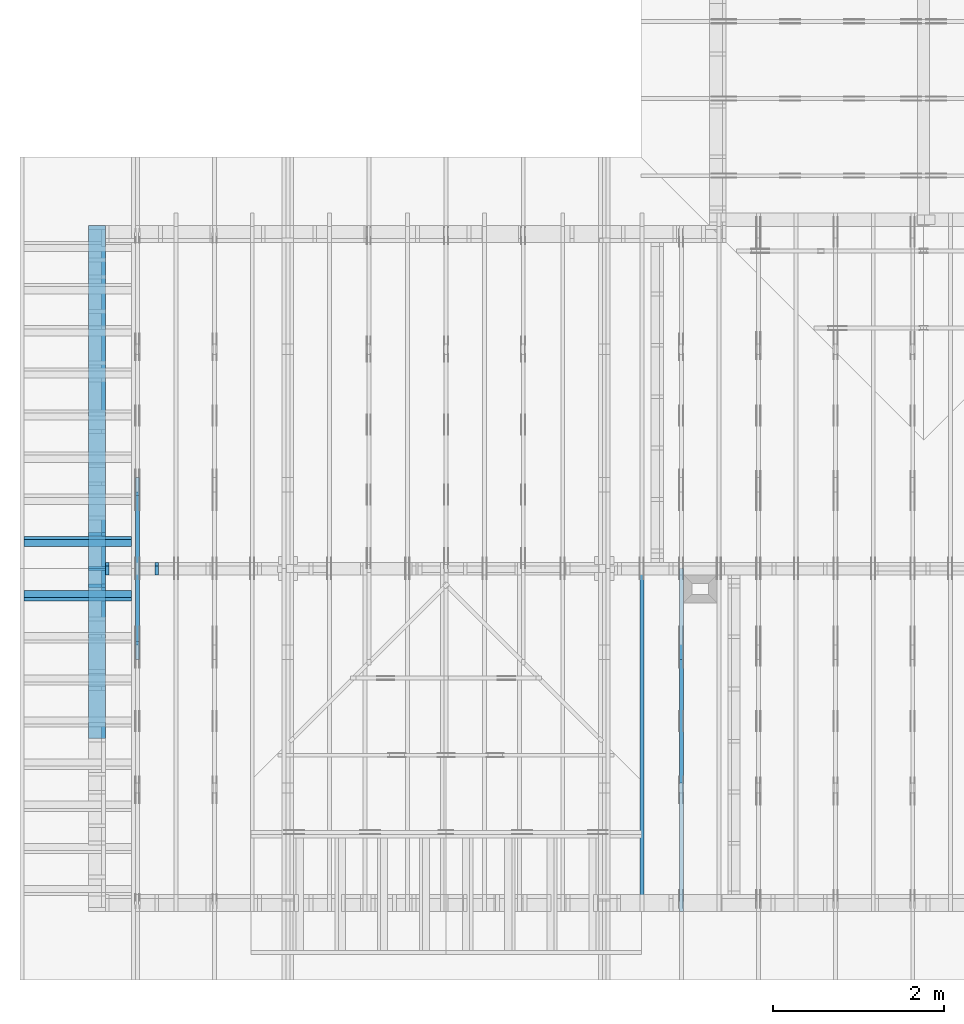
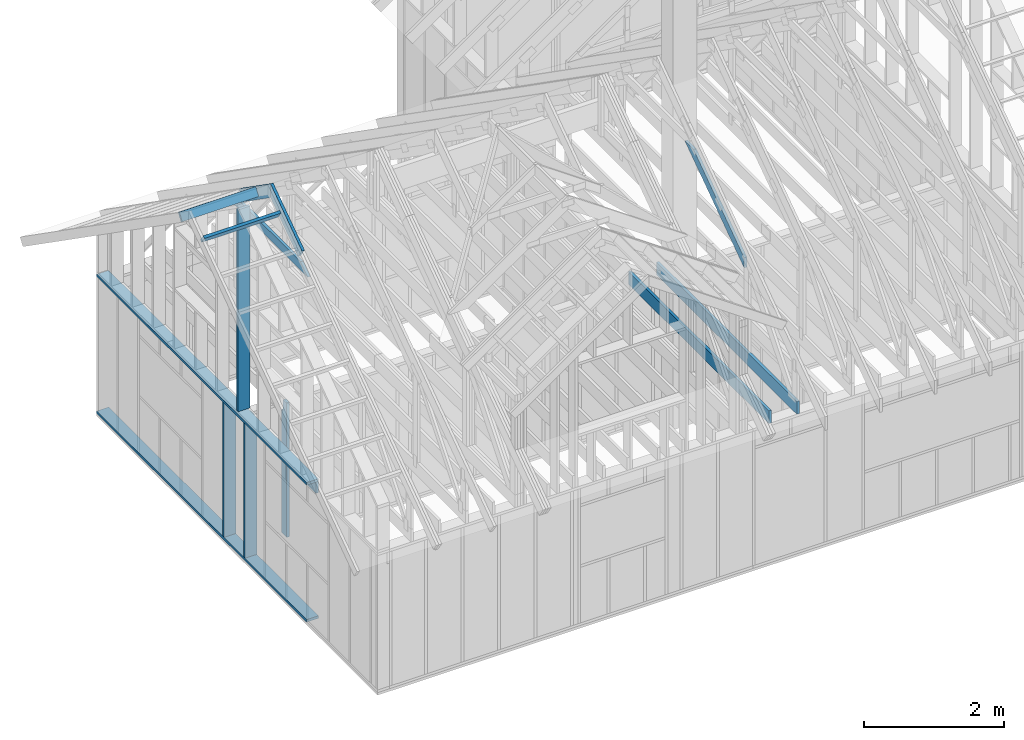
# One storey, part 10 of 70: 16 members, 8 elements without a shape of their own.
"""IFC2X3 building model written with IfcOpenShell, lengths in millimetres."""

import ifcopenshell
import ifcopenshell.guid

model = None  # the IFC model being written
_history = None  # IfcOwnerHistory: only IFC2X3 demands one
_inside = {}  # id of a spatial element -> (the spatial element, [elements in it])
_under = {}  # id of a project, library or spatial element -> (it, [spatial elements below it])
_declared = {}  # id of a project -> (the project, [libraries it declares])
_typed = {}  # id of a type object -> (the type object, [elements of that type])
_made_of = {}  # id of a material, layer set ... -> (it, [elements and type objects made of it])


def new_model(schema):
    """Start an empty IFC model of exactly this schema.

    Asked for "IFC4X3", IfcOpenShell would pick the latest addendum, in which some entities
    have other attributes; the version numbers below select the first issue.
    IFC2X3 requires an IfcOwnerHistory on every rooted entity: one is made here for all.
    """
    global model, _history
    if schema == "IFC4X3":
        model = ifcopenshell.file(schema_version=(4, 3, 0, 0))
    else:
        model = ifcopenshell.file(schema=schema)
    _inside.clear()
    _under.clear()
    _declared.clear()
    _typed.clear()
    _made_of.clear()
    _history = None
    if model.schema == "IFC2X3":
        org = make("IfcOrganization", Name="unknown")
        user = make(
            "IfcPersonAndOrganization",
            ThePerson=make("IfcPerson", FamilyName="unknown"),
            TheOrganization=org,
        )
        app = make(
            "IfcApplication",
            ApplicationDeveloper=org,
            Version="unknown",
            ApplicationFullName="unknown",
            ApplicationIdentifier="unknown",
        )
        _history = make(
            "IfcOwnerHistory",
            OwningUser=user,
            OwningApplication=app,
            ChangeAction="ADDED",
            CreationDate=0,
        )
    return model


def make(cls, **values):
    """One entity of the class cls with the attributes given. An attribute that is None is left unset."""
    return model.create_entity(
        cls, **{name: value for name, value in values.items() if value is not None}
    )


def rooted(cls, **values):
    """An entity with a GlobalId (a new one), such as an element, a storey or a relation."""
    return make(cls, GlobalId=ifcopenshell.guid.new(), OwnerHistory=_history, **values)


def si_unit(unit_type, name, prefix=None):
    """IfcSIUnit, for example si_unit("LENGTHUNIT", "METRE", prefix="MILLI")."""
    return make("IfcSIUnit", UnitType=unit_type, Prefix=prefix, Name=name)


def assignment(units):
    """IfcUnitAssignment: the units of a project."""
    return None if units is None else make("IfcUnitAssignment", Units=units)


def point(xyz):
    """IfcCartesianPoint."""
    return None if xyz is None else make("IfcCartesianPoint", Coordinates=xyz)


def direction(xyz):
    """IfcDirection."""
    return None if xyz is None else make("IfcDirection", DirectionRatios=xyz)


def frame(location, z_axis=None, x_axis=None):
    """IfcAxis2Placement3D, a coordinate frame: its origin and axes. An axis left out is left unset."""
    return make(
        "IfcAxis2Placement3D",
        Location=point(location),
        Axis=direction(z_axis),
        RefDirection=direction(x_axis),
    )


def frame_2d(location, x_axis=None):
    """IfcAxis2Placement2D, a coordinate frame in the plane: its origin and x axis."""
    return make(
        "IfcAxis2Placement2D", Location=point(location), RefDirection=direction(x_axis)
    )


def origin():
    """The frame at (0, 0, 0) with its axes left unset."""
    return frame((0.0, 0.0, 0.0))


def origin_with_axes():
    """The frame at (0, 0, 0) with the z axis (0, 0, 1) and the x axis (1, 0, 0) written out."""
    return frame((0.0, 0.0, 0.0), z_axis=(0.0, 0.0, 1.0), x_axis=(1.0, 0.0, 0.0))


def origin_2d():
    """The frame at (0, 0) in the plane with its x axis left unset."""
    return frame_2d((0.0, 0.0))


def place(relative_to, where):
    """IfcLocalPlacement: puts the frame where relative to a parent placement (None: the world)."""
    return make(
        "IfcLocalPlacement", PlacementRelTo=relative_to, RelativePlacement=where
    )


def context(
    kind, dimensions, precision=None, world=None, true_north=None, identifier=None
):
    """IfcGeometricRepresentationContext, for example the 3D "Model" context."""
    return make(
        "IfcGeometricRepresentationContext",
        ContextIdentifier=identifier,
        ContextType=kind,
        CoordinateSpaceDimension=dimensions,
        Precision=precision,
        WorldCoordinateSystem=world,
        TrueNorth=true_north,
    )


def project(units=None, contexts=None):
    """IfcProject with its units and contexts."""
    return rooted(
        "IfcProject",
        Name="project",
        RepresentationContexts=contexts,
        UnitsInContext=assignment(units),
    )


def spatial(cls, under=None, at=None, **own):
    """A site, building, storey or space (cls), placed at a placement, below another one or the project."""
    s = rooted(cls, ObjectPlacement=at, **own)
    if under is not None:
        _under.setdefault(under.id(), (under, []))[1].append(s)
    return s


def faces_of(points, faces, orient=None, outer=None):
    """IfcFace entities. A face is a list of loops; a loop is a list of indices into points, from 0.

    orient and outer hold one flag for each loop. By default every Orientation is true, the
    first loop of a face is its IfcFaceOuterBound and the others are IfcFaceBound.
    """
    made = []
    for i, loops in enumerate(faces):
        bounds = []
        for j, loop in enumerate(loops):
            is_outer = j == 0 if outer is None else outer[i][j]
            bounds.append(
                make(
                    "IfcFaceOuterBound" if is_outer else "IfcFaceBound",
                    Bound=make("IfcPolyLoop", Polygon=[points[k] for k in loop]),
                    Orientation=True if orient is None else orient[i][j],
                )
            )
        made.append(make("IfcFace", Bounds=bounds))
    return made


def faceted_brep(points, faces, orient=None, outer=None, voids=None):
    """IfcFacetedBrep: a solid bounded by flat faces; with voids (closed shells), ...WithVoids."""
    shared = [point(p) for p in points]
    hull = make("IfcClosedShell", CfsFaces=faces_of(shared, faces, orient, outer))
    if voids is None:
        return make("IfcFacetedBrep", Outer=hull)
    return make(
        "IfcFacetedBrepWithVoids",
        Outer=hull,
        Voids=[
            make(cls, CfsFaces=faces_of(shared, fs, o, b)) for cls, fs, o, b in voids
        ],
    )


def shape(context_of_items, identifier, shape_type, items):
    """IfcShapeRepresentation: the items that make up one representation, for example the "Body"."""
    return make(
        "IfcShapeRepresentation",
        ContextOfItems=context_of_items,
        RepresentationIdentifier=identifier,
        RepresentationType=shape_type,
        Items=items,
    )


def made_of(thing, what):
    """Note that an element or type object is made of a material, layer set ...; save() writes the relation."""
    if what is not None:
        _made_of.setdefault(what.id(), (what, []))[1].append(thing)
    return thing


def element(
    cls,
    number,
    at=None,
    inside=None,
    cuts=None,
    type_object=None,
    material=None,
    context=None,
    identifier="Body",
    shape_type=None,
    held_by="IfcProductDefinitionShape",
    body=None,
    shapes=None,
    **own,
):
    """One element of the class cls, such as IfcWall. Its Tag is "e" and its number.

    at: its placement. inside: the storey or other place that contains it. cuts: it is an
    opening in that element (IfcRelVoidsElement). A single representation is given by context,
    identifier, shape_type and body (its items); several are given by shapes. held_by: the class
    of the entity that holds the representations. save() writes the other relations.
    """
    e = rooted(cls, Tag="e%d" % number, ObjectPlacement=at, **own)
    if body is not None:
        shapes = [shape(context, identifier, shape_type, body)]
    if shapes is not None:
        e.Representation = make(held_by, Representations=shapes)
    if inside is not None:
        _inside.setdefault(inside.id(), (inside, []))[1].append(e)
    if cuts is not None:
        rooted(
            "IfcRelVoidsElement", RelatingBuildingElement=cuts, RelatedOpeningElement=e
        )
    if type_object is not None:
        _typed.setdefault(type_object.id(), (type_object, []))[1].append(e)
    return made_of(e, material)


def aggregate(whole, parts):
    """IfcRelAggregates: a whole, such as a stair, and the parts it consists of."""
    return rooted("IfcRelAggregates", RelatingObject=whole, RelatedObjects=parts)


def save(model, path):
    """Write the relations noted so far, then the file.

    IfcRelAggregates (storeys below a building ...), IfcRelContainedInSpatialStructure (elements
    in a storey), IfcRelDefinesByType, IfcRelAssociatesMaterial and IfcRelDeclares: one each for
    every whole, place, type object, material and project.
    """
    for whole, parts in _under.values():
        aggregate(whole, parts)
    for where, things in _inside.values():
        rooted(
            "IfcRelContainedInSpatialStructure",
            RelatedElements=things,
            RelatingStructure=where,
        )
    for kind, things in _typed.values():
        rooted("IfcRelDefinesByType", RelatedObjects=things, RelatingType=kind)
    for what, things in _made_of.values():
        rooted("IfcRelAssociatesMaterial", RelatedObjects=things, RelatingMaterial=what)
    for by, libraries in _declared.values():
        rooted("IfcRelDeclares", RelatingContext=by, RelatedDefinitions=libraries)
    model.write(path)


model = new_model("IFC2X3")

# Units and contexts
model_context = context("Model", 3, precision=1e-05, world=origin())
plan_context = context("Plan", 2, precision=1e-05, world=origin_2d())
ifc_project = project(units=[si_unit("LENGTHUNIT", "METRE", prefix="MILLI"), si_unit("AREAUNIT", "SQUARE_METRE"), si_unit("VOLUMEUNIT", "CUBIC_METRE"), si_unit("SOLIDANGLEUNIT", "STERADIAN"), si_unit("PLANEANGLEUNIT", "RADIAN"), si_unit("MASSUNIT", "GRAM"), si_unit("TIMEUNIT", "SECOND"), si_unit("THERMODYNAMICTEMPERATUREUNIT", "DEGREE_CELSIUS"), si_unit("LUMINOUSINTENSITYUNIT", "LUMEN")], contexts=[model_context, plan_context])

# Site, building, storey
site_placement = place(None, origin_with_axes())
site = spatial("IfcSite", under=ifc_project, at=site_placement, CompositionType="ELEMENT")
building_placement = place(site_placement, origin_with_axes())
building = spatial("IfcBuilding", under=site, at=building_placement, Name="Layout 1", CompositionType="ELEMENT")
storey_placement = place(building_placement, origin_with_axes())
storey = spatial("IfcBuildingStorey", under=building, at=storey_placement, Name="Storey 1", CompositionType="ELEMENT", Elevation=0.0)

# Assembly, members
assembly_1_placement = place(storey_placement, frame((304.9999999999989, 8000.000000000001, 1.3776821480501744e-15), z_axis=(-1.0, 1.836909530733566e-16, 6.123031769111886e-17), x_axis=(-1.836909530733566e-16, -1.0, 0.0)))
assembly_1 = element("IfcElementAssembly", 1, at=assembly_1_placement, inside=storey, Name="T2", AssemblyPlace="FACTORY", PredefinedType="TRUSS")
member_1_placement = place(assembly_1_placement, frame((3217.690358731264, 3015.0000000002183, -45.00000000000001), z_axis=(0.0, 0.0, 1.0), x_axis=(0.8191520442889918, 0.5735764363510462, 0.0)))
member_1 = element("IfcMember", 2, at=member_1_placement, Name="T18", context=model_context, shape_type="Brep", body=[
    faceted_brep([(1091.564200553914, 194.99999999865213, 45.0), (0.0, 194.99999999865213, 45.0), (1.6370904631912708e-10, 7.557900971733034e-10, 45.0), (955.0237306039635, 7.557900971733034e-10, 45.0), (0.0, 194.99999999865213, 0.0), (1091.564200553914, 194.99999999865213, 1.3367364556033665e-13), (955.0237306039635, 7.557900971733034e-10, 1.169528128548764e-13), (1.6370904631912708e-10, 7.557900971733034e-10, 2.004791383006049e-26), (1.6370904631912732e-10, 7.557900971733033e-10, -1.4349296274686127e-41), (1.6371180168342342e-10, 7.557900971733033e-10, 45.0), (6.660321774678196e-14, 194.99999999996407, 45.0), (6.384785345068161e-14, 194.99999999996407, -3.909424350681179e-30), (955.0237306039635, -1.5956987698560245e-13, 9.770514261762543e-30), (955.0237306039635, -1.568145126895021e-13, 45.0), (1.6370904631912708e-10, 7.557928525375995e-10, 45.0), (1.6370904631912708e-10, 7.557900971733034e-10, 0.0), (1091.564200553914, 194.99999999865213, 0.0), (1091.564200553914, 194.99999999865213, 45.0), (955.0237306039635, -5.684341886080802e-14, 45.0), (955.0237306039635, -5.684341886080802e-14, -6.310887241768095e-30), (0.0, 194.99999999996407, 0.0), (0.0, 194.99999999996407, 45.0), (1091.564200553914, 194.99999999865202, 45.0), (1091.564200553914, 194.99999999865202, -6.310887241768095e-30)], [[[0, 1, 2, 3]], [[4, 5, 6, 7]], [[8, 9, 10, 11]], [[12, 13, 14, 15]], [[16, 17, 18, 19]], [[20, 21, 22, 23]]]),
])
member_2_placement = place(assembly_1_placement, frame((3888.1525949105694, 3641.0955042035366, -45.00000000000001), z_axis=(0.0, 0.0, 1.0), x_axis=(0.8191520442889916, -0.5735764363510465, 0.0)))
member_2 = element("IfcMember", 3, at=member_2_placement, Name="T18", context=model_context, shape_type="Brep", body=[
    faceted_brep([(1091.5642005560503, 194.99999999996362, 45.0), (0.0, 194.99999999996362, 45.0), (136.54046995208614, 0.0, 45.0), (1091.5642005561149, 0.0, 45.0), (0.0, 194.99999999996362, 0.0), (1091.5642005560503, 194.99999999996362, 1.336736455605983e-13), (1091.5642005561149, 0.0, 1.336736455606062e-13), (136.54046995208614, 0.0, 1.6720832705721806e-14), (136.54046995208614, -2.842170943040401e-14, 3.0619884913871384e-31), (136.54046995208614, -2.842170943040401e-14, 45.0), (1.4210854715202004e-14, 195.00000000170263, 45.0), (1.4210854715202004e-14, 195.00000000170263, -5.932810329456638e-31), (1091.5642005561149, 2.0525182992035534e-09, 1.2934457505131873e-29), (1091.5642005561149, 2.0525210545678495e-09, 45.0), (136.54046995208614, -2.3668346958569874e-14, 45.0), (136.54046995208614, -2.6423711254670222e-14, 1.6179322347011683e-30), (1091.5642005561149, 194.99999999996362, 3.950615413346827e-27), (1091.5642005561149, 194.99999999996362, 45.0), (1091.5642005561149, 2.052729541901499e-09, 45.0), (1091.5642005561149, 2.052729541901499e-09, 0.0), (0.0, 195.00000000170257, 0.0), (0.0, 195.00000000170257, 45.0), (1091.5642005560503, 194.9999999999637, 45.0), (1091.5642005560503, 194.9999999999637, 6.310887241768095e-30)], [[[0, 1, 2, 3]], [[4, 5, 6, 7]], [[8, 9, 10, 11]], [[12, 13, 14, 15]], [[16, 17, 18, 19]], [[20, 21, 22, 23]]]),
])
member_3_placement = place(assembly_1_placement, frame((5060.798502586593, 2964.999999998785, -45.0), z_axis=(0.0, 0.0, 1.0), x_axis=(-1.0, 1.2246063538223773e-16, 0.0)))
member_3 = element("IfcMember", 4, at=member_3_placement, Name="C1", context=model_context, shape_type="Brep", body=[
    faceted_brep([(2121.597005175296, 145.00000000000728, 45.0), (0.0, 145.00000000000728, 45.0), (207.08146097743884, 0.0, 45.0), (1914.5155441979737, 0.0, 45.0), (0.0, 145.00000000000728, 0.0), (2121.597005175296, 145.00000000000728, 2.5981211727881944e-13), (1914.5155441979737, 0.0, 2.3445278999165447e-13), (207.08146097743884, 0.0, 2.5359327287179227e-14), (207.08146097743878, -7.105427357601002e-14, 3.1554436208840472e-30), (207.08146097743878, -7.105427357601002e-14, 45.0), (1.4210854715202004e-14, 145.00000000000728, 45.0), (1.4210854715202004e-14, 145.00000000000728, 0.0), (1914.5155441979737, 7.26803319922997e-12, 4.8521444511629875e-31), (1914.5155441979737, 7.27078856352607e-12, 45.0), (207.08146097743884, 1.898228698049977e-15, 45.0), (207.08146097743884, -8.571355980503717e-16, 5.248268497299439e-32), (2121.597005175296, 145.00000000000728, 0.0), (2121.597005175296, 145.00000000000728, 45.0), (1914.515544197974, 7.389644451905042e-12, 45.0), (1914.515544197974, 7.389644451905042e-12, 1.262177448353619e-29), (0.0, 145.00000000000728, 0.0), (-1.6871183120499046e-31, 145.00000000000728, 45.0), (2121.597005175296, 145.00000000000713, 45.0), (2121.597005175296, 145.00000000000713, -7.888609052210118e-30)], [[[0, 1, 2, 3]], [[4, 5, 6, 7]], [[8, 9, 10, 11]], [[12, 13, 14, 15]], [[16, 17, 18, 19]], [[20, 21, 22, 23]]]),
])
aggregate(assembly_1, [member_1, member_2, member_3])

# Assembly, member
assembly_2_placement = place(storey_placement, frame((6188.750000000146, 8000.0, 1.3776821480501744e-15), z_axis=(-1.0, 1.836909530733566e-16, 6.123031769111886e-17), x_axis=(-1.836909530733566e-16, -1.0, 0.0)))
assembly_2 = element("IfcElementAssembly", 5, at=assembly_2_placement, inside=storey, Name="MB1", AssemblyPlace="FACTORY", PredefinedType="TRUSS")
member_4_placement = place(assembly_2_placement, frame((8000.000000000001, 220.0, -45.0), z_axis=(0.0, 0.0, 1.0), x_axis=(-1.0, 1.2246063538223773e-16, 0.0)))
member_4 = element("IfcMember", 6, at=member_4_placement, Name="B3", context=model_context, shape_type="Brep", body=[
    faceted_brep([(4000.0000000000005, 220.0000000000005, 45.0), (0.0, 220.0000000000005, 45.0), (0.0, 0.0, 45.0), (4000.0000000000005, 0.0, 45.0), (0.0, 220.0000000000005, 0.0), (4000.0000000000005, 220.0000000000005, 4.89842541528951e-13), (4000.0000000000005, 0.0, 4.89842541528951e-13), (0.0, 0.0, 0.0), (0.0, 0.0, 0.0), (2.755364296100349e-15, -3.3742366240998092e-31, 45.0), (2.969670408019265e-14, 220.0, 45.0), (2.69413397840923e-14, 220.0, -1.6496267940043512e-30), (4000.0000000000005, -7.347638122934265e-13, 7.631468701413364e-29), (4000.0000000000005, -7.320084479973261e-13, 45.0), (5.061354936149714e-31, 2.755364296100349e-15, 45.0), (0.0, 0.0, 0.0), (4000.0000000000005, 220.0000000000005, 0.0), (4000.0000000000005, 220.0000000000005, 45.0), (4000.0000000000005, 5.115907697472721e-13, 45.0), (4000.0000000000005, 5.115907697472721e-13, 0.0), (0.0, 220.0, 0.0), (0.0, 220.0, 45.0), (4000.0000000000005, 220.00000000000065, 45.0), (4000.0000000000005, 220.00000000000065, 7.888609052210118e-30)], [[[0, 1, 2, 3]], [[4, 5, 6, 7]], [[8, 9, 10, 11]], [[12, 13, 14, 15]], [[16, 17, 18, 19]], [[20, 21, 22, 23]]]),
])
aggregate(assembly_2, [member_4])

# Assembly, members
assembly_3_placement = place(storey_placement, frame((-243.55339059327574, 8000.000000000001, -2470.0), z_axis=(-1.0, 1.836909530733566e-16, 6.123031769111886e-17), x_axis=(-1.836909530733566e-16, -1.0, 0.0)))
assembly_3 = element("IfcElementAssembly", 7, at=assembly_3_placement, inside=storey, Name="VE3", AssemblyPlace="FACTORY", PredefinedType="NOTDEFINED")
member_5_placement = place(assembly_3_placement, frame((1.457281561048629e-13, 2425.0, -195.0), z_axis=(0.0, 0.0, 1.0), x_axis=(1.0, 0.0, 0.0)))
member_5 = element("IfcMember", 8, at=member_5_placement, Name="P1", context=model_context, shape_type="Brep", body=[
    faceted_brep([(5979.999999999998, 45.0, 195.0), (2.755364296100349e-15, 45.0, 195.0), (0.0, 0.0, 195.0), (5979.999999999998, 0.0, 195.0), (2.755364296100349e-15, 45.0, 3.3742366240998092e-31), (5979.999999999998, 45.0, 7.323145995857814e-13), (5979.999999999998, 0.0, 7.323145995857814e-13), (0.0, 0.0, 0.0), (0.0, 0.0, 0.0), (1.1939911949768178e-14, -1.462169203776584e-30, 195.0), (1.7450640541968876e-14, 45.0, 195.0), (5.510728592200698e-15, 45.0, -1.6871183120499046e-31), (5979.999999999998, -1.098471899378672e-12, 6.725978337372284e-29), (5979.999999999998, -1.0865319874289038e-12, 195.0), (2.193253805664876e-30, 1.1939911949768178e-14, 195.0), (0.0, 0.0, 0.0), (5979.999999999998, 45.0, 0.0), (5979.999999999998, 45.0, 195.0), (5979.999999999998, 0.0, 195.0), (5979.999999999998, 0.0, 0.0), (2.755364296100349e-15, 45.0, 0.0), (2.755364296100348e-15, 44.999999999999986, 195.0), (5979.999999999998, 44.99999999999962, 195.0), (5979.999999999998, 44.99999999999963, -2.2482535798798836e-29)], [[[0, 1, 2, 3]], [[4, 5, 6, 7]], [[8, 9, 10, 11]], [[12, 13, 14, 15]], [[16, 17, 18, 19]], [[20, 21, 22, 23]]]),
])
member_6_placement = place(assembly_3_placement, frame((5980.0, 90.0, -195.0), z_axis=(0.0, 0.0, 1.0), x_axis=(-1.0, 1.2246063538223773e-16, 0.0)))
member_6 = element("IfcMember", 9, at=member_6_placement, Name="P1", context=model_context, shape_type="Brep", body=[
    faceted_brep([(5980.0, 45.00000000000074, 195.0), (0.0, 45.00000000000074, 195.0), (0.0, 0.0, 195.0), (5980.0, 0.0, 195.0), (0.0, 45.00000000000074, 0.0), (5980.0, 45.00000000000074, 7.323145995857816e-13), (5980.0, 0.0, 7.323145995857816e-13), (0.0, 0.0, 0.0), (0.0, 0.0, 0.0), (1.1939911949768178e-14, -1.462169203776584e-30, 195.0), (1.7450640541968876e-14, 45.00000000000001, 195.0), (5.5107285922006985e-15, 45.00000000000001, -3.3742366240998097e-31), (5980.0, -1.0984718993786724e-12, 1.1250681111517883e-28), (5980.0, -1.0865319874289042e-12, 195.0), (2.193253805664876e-30, 1.1939911949768178e-14, 195.0), (0.0, 0.0, 0.0), (5980.0, 45.00000000000074, 0.0), (5980.0, 45.00000000000074, 195.0), (5980.0, 7.389644451905042e-13, 195.0), (5980.0, 7.389644451905042e-13, 0.0), (0.0, 45.00000000000001, 0.0), (1.5777218104420236e-30, 44.99999999999999, 195.0), (5980.0, 45.00000000000096, 195.0), (5980.0, 45.000000000000966, 1.3805065841367707e-29)], [[[0, 1, 2, 3]], [[4, 5, 6, 7]], [[8, 9, 10, 11]], [[12, 13, 14, 15]], [[16, 17, 18, 19]], [[20, 21, 22, 23]]]),
])
member_7_placement = place(assembly_3_placement, frame((1.3378824415499132e-13, 2229.9999999981374, -195.0), z_axis=(0.0, 0.0, 1.0), x_axis=(1.0, 0.0, 0.0)))
member_7 = element("IfcMember", 10, at=member_7_placement, Name="L1", context=model_context, shape_type="Brep", body=[
    faceted_brep([(5980.0, 195.00000000186265, 45.0), (1.1939911949871576e-14, 195.00000000186265, 45.0), (0.0, 0.0, 45.0), (5980.0, 0.0, 45.0), (1.1939911949871576e-14, 195.00000000186265, 1.4621692037892461e-30), (5980.0, 195.00000000186265, 7.323145995857816e-13), (5980.0, 0.0, 7.323145995857816e-13), (0.0, 0.0, 0.0), (0.0, 0.0, 0.0), (2.755364296100349e-15, -3.3742366240998092e-31, 45.0), (2.6635188195864806e-14, 195.00000000186265, 45.0), (2.3879823899764457e-14, 195.00000000186265, -7.310846018959277e-31), (5980.0, 1.86317026748279e-09, -3.2153157385149134e-29), (5980.0, 1.8631730228470863e-09, 45.0), (-8.584804067855881e-28, 2.755364296100349e-15, 45.0), (0.0, 0.0, 0.0), (5980.0, 195.00000000186265, 0.0), (5980.0, 195.00000000186265, 45.0), (5980.0, 1.862645149230957e-09, 45.0), (5980.0, 1.862645149230957e-09, 0.0), (1.1939911949871576e-14, 195.00000000186265, 0.0), (1.1939911949871576e-14, 195.00000000186265, 45.0), (5980.0, 195.00000000186228, 45.0), (5980.0, 195.00000000186228, -2.208810534618833e-29)], [[[0, 1, 2, 3]], [[4, 5, 6, 7]], [[8, 9, 10, 11]], [[12, 13, 14, 15]], [[16, 17, 18, 19]], [[20, 21, 22, 23]]]),
])
member_8_placement = place(assembly_3_placement, frame((3577.5000000018194, 2425.0, -195.0), z_axis=(0.0, 0.0, 1.0), x_axis=(-1.836909530733566e-16, -1.0, 0.0)))
member_8 = element("IfcMember", 11, at=member_8_placement, Name="S11", context=model_context, shape_type="Brep", body=[
    faceted_brep([(0.0, 44.999999999999545, 45.0), (195.00000000186265, 44.999999999999545, 45.00000000000002), (195.00000000186265, 1.4097167877480388e-11, 45.00000000000002), (0.0, 1.4097167877480388e-11, 45.0), (195.00000000186265, 1.2732925824820995e-11, 0.0), (195.00000000186265, 1.2732925824820995e-11, 45.0), (195.00000000186265, 45.00000000000091, 45.0), (195.00000000186265, 45.00000000000091, 0.0), (2.7553642961020753e-15, 1.4097167877480388e-11, 45.0), (1.1939911949769904e-14, 1.4097167877480388e-11, 195.0), (1.7450640541968822e-14, 44.999999999999545, 195.00000000000003), (8.26609288830099e-15, 44.999999999999545, 45.0), (2335.0, 1.36682495020541e-11, 2.626280839091018e-29), (2335.0, 1.3680189414003868e-11, 195.0), (2.193253805664876e-30, 1.4109107789430156e-11, 195.0), (5.061354936149714e-31, 1.4099923241776488e-11, 45.0), (195.00000000186265, 1.4064103505926841e-11, 45.0), (195.00000000186265, 1.406134814163074e-11, 2.193253805685862e-30), (-1.6871183120499046e-31, 45.00000000000091, 45.0), (-7.31084601888292e-31, 45.000000000000895, 195.0), (2335.0, 45.00000000000075, 195.0), (2335.0, 45.00000000000077, -8.67746995743113e-30), (195.00000000186265, 45.000000000000895, -7.888609052210118e-31), (195.00000000186265, 45.000000000000895, 45.0), (2335.0, 45.00000000001455, 0.0), (2335.0, 45.00000000001455, 195.0), (2335.0, 0.0, 195.0), (2335.0, 0.0, 0.0), (2335.0, 45.00000000001455, 195.0), (0.0, 45.00000000001455, 195.0), (0.0, 1.4097167877480388e-11, 195.0), (2335.0, 1.4097167877480388e-11, 195.0), (195.00000000186265, 45.00000000000091, 2.3879823899764457e-14), (2335.0, 45.00000000000091, 2.859455836175251e-13), (2335.0, 0.0, 2.859455836175251e-13), (195.00000000186265, 0.0, 2.3879823899764457e-14)], [[[0, 1, 2, 3]], [[4, 5, 6, 7]], [[8, 9, 10, 11]], [[12, 13, 14, 15, 16, 17]], [[18, 19, 20, 21, 22, 23]], [[24, 25, 26, 27]], [[28, 29, 30, 31]], [[32, 33, 34, 35]]]),
])
member_9_placement = place(assembly_3_placement, frame((4177.500000001819, 2425.0, -195.00000000000003), z_axis=(0.0, 0.0, 1.0), x_axis=(-1.836909530733566e-16, -1.0, 0.0)))
member_9 = element("IfcMember", 12, at=member_9_placement, Name="S11", context=model_context, shape_type="Brep", body=[
    faceted_brep([(0.0, 45.00000000001455, 45.00000000000003), (195.00000000186265, 45.00000000001455, 45.00000000000005), (195.00000000186265, 0.0, 45.00000000000005), (0.0, 0.0, 45.00000000000003), (195.00000000186265, -2.1311460639909362e-46, 2.842170943040401e-14), (195.00000000186265, -3.3742366240998114e-31, 45.00000000000003), (195.00000000186265, 45.00000000001364, 45.00000000000003), (195.00000000186265, 45.00000000001364, 2.842170943040401e-14), (2.7553642961003504e-15, -3.3742366240998114e-31, 45.00000000000003), (1.1939911949768181e-14, -1.4621692037765844e-30, 195.00000000000006), (1.7450640541970662e-14, 45.00000000001455, 195.00000000000006), (8.26609288830283e-15, 45.00000000001455, 45.00000000000003), (2335.0, -4.2891837542628763e-13, 2.842170943040403e-14), (2335.0, -4.1697846347651946e-13, 195.00000000000003), (2.1932538056648764e-30, 1.193991194976818e-14, 195.00000000000003), (5.061354936149717e-31, 2.7553642961003504e-15, 45.00000000000003), (195.00000000186265, -3.306437155354634e-14, 45.00000000000003), (195.00000000186265, -3.5819735849646686e-14, 2.842170943040401e-14), (-1.6871183120499057e-31, 45.00000000001364, 45.00000000000003), (-7.310846018882921e-31, 45.00000000001363, 195.00000000000003), (2335.0, 45.000000000013486, 195.00000000000003), (2335.0, 45.0000000000135, 2.8421709430403998e-14), (195.00000000186265, 45.00000000001363, 2.842170943040401e-14), (195.00000000186265, 45.00000000001363, 45.00000000000003), (2335.0, 45.0, 0.0), (2335.0, 45.0, 195.00000000000003), (2335.0, 0.0, 195.00000000000003), (2335.0, 0.0, 0.0), (2335.0, 45.0, 195.00000000000003), (0.0, 45.0, 195.00000000000003), (0.0, 0.0, 195.00000000000003), (2335.0, 0.0, 195.00000000000003), (195.00000000186265, 45.00000000001364, 5.2301533330168465e-14), (2335.0, 45.00000000001364, 3.143672930479291e-13), (2335.0, 0.0, 3.143672930479291e-13), (195.00000000186265, 0.0, 5.2301533330168465e-14)], [[[0, 1, 2, 3]], [[4, 5, 6, 7]], [[8, 9, 10, 11]], [[12, 13, 14, 15, 16, 17]], [[18, 19, 20, 21, 22, 23]], [[24, 25, 26, 27]], [[28, 29, 30, 31]], [[32, 33, 34, 35]]]),
])
aggregate(assembly_3, [member_5, member_6, member_7, member_8, member_9])

# Assembly, member
assembly_4_placement = place(storey_placement, frame((-48.55339059327645, 2.2546681725408788e-11, 1.1939911949768178e-14), z_axis=(1.0, 1.156240088482502e-13, 6.123031769111886e-17), x_axis=(-1.156240088482502e-13, 1.0, 0.0)))
assembly_4 = element("IfcElementAssembly", 13, at=assembly_4_placement, inside=storey, Name="VEg1", AssemblyPlace="FACTORY", PredefinedType="NOTDEFINED")
member_10_placement = place(assembly_4_placement, frame((4022.499999999389, 44.99999999999999, -195.0), z_axis=(0.0, 0.0, 1.0), x_axis=(6.123031769111886e-17, 1.0, 0.0)))
member_10 = element("IfcMember", 14, at=member_10_placement, Name="S3", context=model_context, shape_type="Brep", body=[
    faceted_brep([(3508.128311364242, 45.0, 195.0), (0.0, 45.0, 195.0), (7.105427357601002e-15, 0.0, 195.0), (3508.1283113651007, 0.0, 195.0), (3523.882980974391, 22.499999999387455, 195.0), (0.0, 45.0, 0.0), (3508.128311364242, 45.0, 4.296076220120818e-13), (3523.882980974391, 22.499999999387455, 4.3153694886277787e-13), (3508.1283113651007, 0.0, 4.2960762201218694e-13), (7.105427357601002e-15, 0.0, 8.701351488741532e-31), (7.105427357601001e-15, 1.7516230804060213e-46, 8.758115402030107e-47), (1.904533930736918e-14, -1.4621692037765838e-30, 195.0), (2.4556067899569878e-14, 45.0, 195.0), (1.26161559498017e-14, 45.0, -7.724912368470574e-31), (3508.1283113651007, -6.444114330182804e-13, 3.9457516767498473e-29), (3508.1283113651007, -6.324715210685122e-13, 195.0), (7.105427357601003e-15, 1.1939911949768177e-14, 195.0), (7.105427357601002e-15, -1.3052027233112297e-30, 7.991797739966011e-47), (3523.882980974392, 22.499999999387, 7.573064690121713e-29), (3523.882980974392, 22.499999999387, 195.0), (3508.1283113651016, -4.547473508864641e-13, 195.0), (3508.1283113651016, -4.547473508864641e-13, 7.573064690121713e-29), (3508.128311364242, 45.0, 0.0), (3508.128311364242, 45.0, 195.0), (3523.882980974391, 22.499999999387683, 195.0), (3523.882980974391, 22.499999999387683, 2.524354896707238e-29), (0.0, 45.0, 0.0), (-7.31084601888292e-31, 44.999999999999986, 195.0), (3508.128311364242, 44.99999999999977, 195.0), (3508.128311364242, 44.99999999999979, -1.3016204936146695e-29)], [[[0, 1, 2, 3, 4]], [[5, 6, 7, 8, 9]], [[10, 11, 12, 13]], [[14, 15, 16, 17]], [[18, 19, 20, 21]], [[22, 23, 24, 25]], [[26, 27, 28, 29]]]),
])
aggregate(assembly_4, [member_10])

# Assembly, members
assembly_5_placement = place(storey_placement, frame((-48.55339059327651, 3927.500000000001, -2470.0), z_axis=(0.0, -1.0, 6.123031769111886e-17), x_axis=(1.0, 0.0, 0.0)))
assembly_5 = element("IfcElementAssembly", 15, at=assembly_5_placement, inside=storey, Name="VE8", AssemblyPlace="FACTORY", PredefinedType="NOTDEFINED")
member_11_placement = place(assembly_5_placement, frame((44.999999999999865, 90.0000000000013, -145.00000000000003), z_axis=(0.0, 0.0, 1.0), x_axis=(6.123031769111886e-17, 1.0, 0.0)))
member_11 = element("IfcMember", 16, at=member_11_placement, Name="S42", context=model_context, shape_type="Brep", body=[
    faceted_brep([(2139.999999998136, 44.99999999999999, 2.842170943040401e-14), (2139.999999998136, 44.99999999999999, 45.00000000000003), (2139.999999998136, 1.5553780485788593e-10, 45.00000000000003), (2139.999999998136, 1.5553780485788593e-10, 2.842170943040401e-14), (2139.999999998136, 44.99999999999999, 45.00000000000029), (2334.9999999999986, 44.99999999999999, 45.00000000000031), (2334.9999999999986, 1.5554491028524353e-10, 45.00000000000031), (2139.999999998136, 1.5554491028524353e-10, 45.00000000000029), (7.105427357601002e-14, 45.00000000000001, 2.842170943040401e-14), (7.105427357601002e-14, 45.0, 145.00000000000003), (2334.9999999999986, 44.99999999999986, 145.00000000000003), (2334.9999999999986, 44.99999999999986, 45.00000000000003), (2139.999999998136, 44.99999999999987, 45.00000000000003), (2139.999999998136, 44.99999999999988, 2.8421709430403998e-14), (7.105427357601002e-14, 44.999999999999865, 2.8421709430404014e-14), (2139.999999998136, 44.999999999999865, 2.904874691481645e-13), (2139.999999998136, 1.5554491028524353e-10, 2.904874691481645e-13), (7.105427357601002e-14, 1.5554491028524353e-10, 2.8421709430404014e-14), (8.52651282910725e-14, 1.8625101461111626e-09, 2.842170943040401e-14), (1.5853645978454382e-13, 1.8625101461111626e-09, 145.00000000000003), (8.411113060681386e-14, 44.999999999999865, 145.00000000000003), (1.0839799113342537e-14, 44.999999999999865, -5.477562166595574e-30), (2334.9999999999986, 1.5511874727411334e-10, 45.00000000000003), (2334.9999999999986, 1.5512487030588246e-10, 145.00000000000003), (7.105427357601002e-14, 1.5555378868130874e-10, 145.00000000000003), (7.105427357601002e-14, 1.5554491028524353e-10, 2.842170943040401e-14), (2139.999999998136, 1.5515181164566688e-10, 2.842170943040403e-14), (2139.999999998136, 1.5515456700996298e-10, 45.00000000000003), (2334.9999999999986, 45.00000000000001, 45.00000000000003), (2334.9999999999986, 45.00000000000001, 145.0), (2334.9999999999986, 0.0, 145.00000000000003), (2334.9999999999986, 0.0, 45.00000000000003), (2334.9999999999986, 45.00000000000001, 145.00000000000003), (7.105427357601002e-14, 45.00000000000001, 145.00000000000003), (7.105427357601002e-14, 1.8625101461111626e-09, 145.00000000000003), (2334.9999999999986, 1.8625101461111626e-09, 145.00000000000003)], [[[0, 1, 2, 3]], [[4, 5, 6, 7]], [[8, 9, 10, 11, 12, 13]], [[14, 15, 16, 17]], [[18, 19, 20, 21]], [[22, 23, 24, 25, 26, 27]], [[28, 29, 30, 31]], [[32, 33, 34, 35]]]),
])
member_12_placement = place(assembly_5_placement, frame((577.5000000018194, 2425.0, -145.0), z_axis=(0.0, 0.0, 1.0), x_axis=(-1.836909530733566e-16, -1.0, 0.0)))
member_12 = element("IfcMember", 17, at=member_12_placement, Name="S42", context=model_context, shape_type="Brep", body=[
    faceted_brep([(0.0, 45.00000000002865, 45.0), (195.00000000186265, 45.00000000002865, 45.00000000000002), (195.00000000186265, 1.4097167877480388e-11, 45.00000000000002), (0.0, 1.4097167877480388e-11, 45.0), (195.00000000186265, 1.2846612662542611e-11, 0.0), (195.00000000186265, 1.2846612662542611e-11, 45.0), (195.00000000186265, 45.0000000000274, 45.0), (195.00000000186265, 45.0000000000274, 0.0), (2.7553642961020753e-15, 1.4097167877480388e-11, 45.0), (8.878396065213961e-15, 1.4097167877480388e-11, 145.0), (1.4389124657416442e-14, 45.00000000002865, 145.0), (8.266092888304555e-15, 45.00000000002865, 45.0), (2335.0, 1.36682495020541e-11, 2.626280839091018e-29), (2335.0, 1.3677127898119312e-11, 145.0), (1.6308810349815745e-30, 1.41060462735456e-11, 145.0), (5.061354936149714e-31, 1.4099923241776488e-11, 45.0), (195.00000000186265, 1.4064103505926841e-11, 45.0), (195.00000000186265, 1.406134814163074e-11, 2.193253805685862e-30), (-1.6871183120499046e-31, 45.0000000000274, 45.0), (-5.436270116605248e-31, 45.00000000002739, 145.0), (2335.0, 45.00000000002725, 145.0), (2335.0, 45.000000000027256, -1.5777218104420236e-29), (195.00000000186265, 45.000000000027384, -7.888609052210118e-31), (195.00000000186265, 45.000000000027384, 45.0), (2335.0, 45.00000000001455, 2.842170943040401e-14), (2335.0, 45.00000000001455, 145.0), (2335.0, 0.0, 145.0), (2335.0, 0.0, 2.842170943040401e-14), (2335.0, 45.00000000001455, 145.0), (0.0, 45.00000000001455, 145.0), (0.0, 1.4097167877480388e-11, 145.0), (2335.0, 1.4097167877480388e-11, 145.0), (195.00000000186265, 45.0000000000274, 2.3879823899764457e-14), (2335.0, 45.0000000000274, 2.859455836175251e-13), (2335.0, 0.0, 2.859455836175251e-13), (195.00000000186265, 0.0, 2.3879823899764457e-14)], [[[0, 1, 2, 3]], [[4, 5, 6, 7]], [[8, 9, 10, 11]], [[12, 13, 14, 15, 16, 17]], [[18, 19, 20, 21, 22, 23]], [[24, 25, 26, 27]], [[28, 29, 30, 31]], [[32, 33, 34, 35]]]),
])
aggregate(assembly_5, [member_11, member_12])

assembly_6_placement = place(storey_placement, frame((6650.000000000001, 8000.0, -9.081170196248781e-13), z_axis=(-1.0, 1.836909530733566e-16, 6.123031769111886e-17), x_axis=(-1.836909530733566e-16, -1.0, 0.0)))
assembly_6 = element("IfcElementAssembly", 18, at=assembly_6_placement, inside=storey, Name="T12", AssemblyPlace="FACTORY", PredefinedType="TRUSS")
member_13_placement = place(assembly_6_placement, frame((7999.999999999999, 220.0, -45.0), z_axis=(0.0, 0.0, 1.0), x_axis=(-1.0, 1.2246063538223773e-16, 0.0)))
member_13 = element("IfcMember", 19, at=member_13_placement, Name="B3", context=model_context, shape_type="Brep", body=[
    faceted_brep([(3999.9999999999995, 220.00000000000048, 45.0), (0.0, 220.00000000000048, 45.0), (0.0, 0.0, 45.0), (3999.9999999999995, 0.0, 45.0), (0.0, 220.00000000000048, 0.0), (3999.9999999999995, 220.00000000000048, 4.898425415289508e-13), (3999.9999999999995, 0.0, 4.898425415289508e-13), (0.0, 0.0, 0.0), (0.0, 0.0, 0.0), (2.755364296100349e-15, -3.3742366240998092e-31, 45.0), (2.969670408019265e-14, 220.0, 45.0), (2.69413397840923e-14, 220.0, -1.6496267940043512e-30), (3999.9999999999995, -7.347638122934263e-13, 7.457441671638533e-29), (3999.9999999999995, -7.320084479973259e-13, 45.0), (5.061354936149714e-31, 2.755364296100349e-15, 45.0), (0.0, 0.0, 0.0), (3999.9999999999995, 220.00000000000048, 0.0), (3999.9999999999995, 220.00000000000048, 45.0), (3999.9999999999995, 4.831690603168681e-13, 45.0), (3999.9999999999995, 4.831690603168681e-13, 0.0), (0.0, 220.0, 0.0), (0.0, 220.0, 45.0), (3999.9999999999995, 220.00000000000065, 45.0), (3999.9999999999995, 220.00000000000065, 9.466330862652142e-30)], [[[0, 1, 2, 3]], [[4, 5, 6, 7]], [[8, 9, 10, 11]], [[12, 13, 14, 15]], [[16, 17, 18, 19]], [[20, 21, 22, 23]]]),
])
member_14_placement = place(assembly_6_placement, frame((6583.168583270521, 1754.024964554012, -44.99999999999999), z_axis=(0.0, 0.0, 1.0), x_axis=(-0.8191520442890866, 0.5735764363509106, 0.0)))
member_14 = element("IfcMember", 20, at=member_14_placement, Name="SC5", context=model_context, shape_type="Brep", body=[
    faceted_brep([(2065.552220741256, 145.00000000323507, 45.0), (0.0, 145.00000000323507, 45.0), (101.53009304067928, 0.0, 45.0), (1858.4707597638994, 0.0, 45.0), (0.0, 145.00000000323507, 0.0), (2065.552220741256, 145.00000000323507, 2.5294883736716636e-13), (1858.4707597638994, 0.0, 2.275895100799972e-13), (101.53009304067928, 0.0, 1.2433439704179296e-14), (101.53009304067926, -1.4210854715202004e-14, 1.2188192559213497e-30), (101.53009304067926, -1.4210854715202004e-14, 45.0), (2.842170943040401e-14, 145.0000000003174, 45.0), (2.842170943040401e-14, 145.0000000003174, -8.457017451291223e-31), (1858.4707597638994, 3.6386987741452655e-09, 1.1604838111769461e-29), (1858.4707597638994, 3.6387015295095616e-09, 45.0), (101.53009304067928, -7.598718304623376e-15, 45.0), (101.53009304067928, -1.0354082600723725e-14, 6.339837670416306e-31), (2065.552220741256, 145.00000000323575, -3.7865323450608567e-29), (2065.552220741256, 145.00000000323575, 45.0), (1858.4707597638994, 3.639456735982094e-09, 45.0), (1858.4707597638994, 3.639456735982094e-09, -3.7865323450608567e-29), (0.0, 145.0000000003174, 0.0), (0.0, 145.0000000003174, 45.0), (2065.552220741256, 145.00000000323564, 45.0), (2065.552220741256, 145.00000000323564, 3.6287601640166543e-29)], [[[0, 1, 2, 3]], [[4, 5, 6, 7]], [[8, 9, 10, 11]], [[12, 13, 14, 15]], [[16, 17, 18, 19]], [[20, 21, 22, 23]]]),
])
aggregate(assembly_6, [member_13, member_14])

# Assembly, member
assembly_7_placement = place(storey_placement, frame((304.99999999999886, -800.0, 439.83396943223215), z_axis=(-2.4046889635939937e-17, -0.573576436351046, 0.8191520442889918), x_axis=(1.5036672491230068e-17, 0.8191520442889918, 0.573576436351046)))
assembly_7 = element("IfcElementAssembly", 21, at=assembly_7_placement, inside=storey, Name="gs1", AssemblyPlace="FACTORY", PredefinedType="TRUSS")
member_15_placement = place(assembly_7_placement, frame((5444.999999998996, 45.0, -145.0), z_axis=(0.0, 0.0, 1.0), x_axis=(6.123031769111886e-17, 1.0, 0.0)))
member_15 = element("IfcMember", 22, at=member_15_placement, Name="W4", context=model_context, shape_type="Brep", body=[
    faceted_brep([(1258.5533905932764, 45.00000000001455, 145.0), (0.0, 45.00000000001455, 145.0), (0.0, 1.4551915228366852e-11, 145.0), (1258.5533905932764, 1.4551915228366852e-11, 145.0), (0.0, 45.00000000001455, 0.0), (1258.5533905932764, 45.00000000001455, 1.5412324787452224e-13), (1258.5533905932764, 1.4551915228366852e-11, 1.5412324787452224e-13), (0.0, 1.4551915228366852e-11, 0.0), (1.7820367848942657e-27, 1.4551915228366852e-11, -1.0911467847633593e-43), (8.878396065214018e-15, 1.4551915228366852e-11, 145.0), (1.4389124657414716e-14, 45.00000000001455, 145.0), (5.51072859220248e-15, 45.00000000001455, -3.3742366241009005e-31), (1258.5533905932764, -2.1092914379474964e-13, 1.2915258484868272e-29), (1258.5533905932764, -2.020507477295374e-13, 145.0), (1.0414367826171774e-28, 1.4560793624432064e-11, 145.0), (0.0, 1.4551915228366852e-11, 0.0), (1258.5533905932764, 45.00000000001455, 0.0), (1258.5533905932764, 45.00000000001455, 145.0), (1258.5533905932764, 0.0, 145.0), (1258.5533905932764, 0.0, 0.0), (-1.2154326714572542e-63, 45.00000000001455, 0.0), (-5.436270116605248e-31, 45.000000000014545, 145.0), (1258.5533905932764, 45.00000000001447, 145.0), (1258.5533905932764, 45.000000000014474, -4.733165431326071e-30)], [[[0, 1, 2, 3]], [[4, 5, 6, 7]], [[8, 9, 10, 11]], [[12, 13, 14, 15]], [[16, 17, 18, 19]], [[20, 21, 22, 23]]]),
])
aggregate(assembly_7, [member_15])

assembly_8_placement = place(storey_placement, frame((-1043.5533905932762, 8800.000000000002, 439.83396943223045), z_axis=(9.428742447176872e-17, 0.5735764363510464, 0.8191520442889916), x_axis=(-1.153505523095189e-16, -0.8191520442889916, 0.5735764363510464)))
assembly_8 = element("IfcElementAssembly", 23, at=assembly_8_placement, inside=storey, Name="gs1", AssemblyPlace="FACTORY", PredefinedType="TRUSS")
member_16_placement = place(assembly_8_placement, frame((5444.999999998996, 45.0, -145.0), z_axis=(0.0, 0.0, 1.0), x_axis=(6.123031769111886e-17, 1.0, 0.0)))
member_16 = element("IfcMember", 24, at=member_16_placement, Name="W4", context=model_context, shape_type="Brep", body=[
    faceted_brep([(1258.5533905932764, 45.00000000001455, 145.0), (0.0, 45.00000000001455, 145.0), (0.0, 1.4551915228366852e-11, 145.0), (1258.5533905932764, 1.4551915228366852e-11, 145.0), (0.0, 45.00000000001455, 0.0), (1258.5533905932764, 45.00000000001455, 1.5412324787452224e-13), (1258.5533905932764, 1.4551915228366852e-11, 1.5412324787452224e-13), (0.0, 1.4551915228366852e-11, 0.0), (1.7820367848942657e-27, 1.4551915228366852e-11, -1.0911467847633593e-43), (8.878396065214018e-15, 1.4551915228366852e-11, 145.0), (1.4389124657414716e-14, 45.00000000001455, 145.0), (5.51072859220248e-15, 45.00000000001455, -3.3742366241009005e-31), (1258.5533905932764, -2.1092914379474964e-13, 1.2915258484868272e-29), (1258.5533905932764, -2.020507477295374e-13, 145.0), (1.0414367826171774e-28, 1.4560793624432064e-11, 145.0), (0.0, 1.4551915228366852e-11, 0.0), (1258.5533905932764, 45.00000000001455, 0.0), (1258.5533905932764, 45.00000000001455, 145.0), (1258.5533905932764, 0.0, 145.0), (1258.5533905932764, 0.0, 0.0), (-1.2154326714572542e-63, 45.00000000001455, 0.0), (-5.436270116605248e-31, 45.000000000014545, 145.0), (1258.5533905932764, 45.00000000001447, 145.0), (1258.5533905932764, 45.000000000014474, -4.733165431326071e-30)], [[[0, 1, 2, 3]], [[4, 5, 6, 7]], [[8, 9, 10, 11]], [[12, 13, 14, 15]], [[16, 17, 18, 19]], [[20, 21, 22, 23]]]),
])
aggregate(assembly_8, [member_16])

save(model, "model.ifc")
